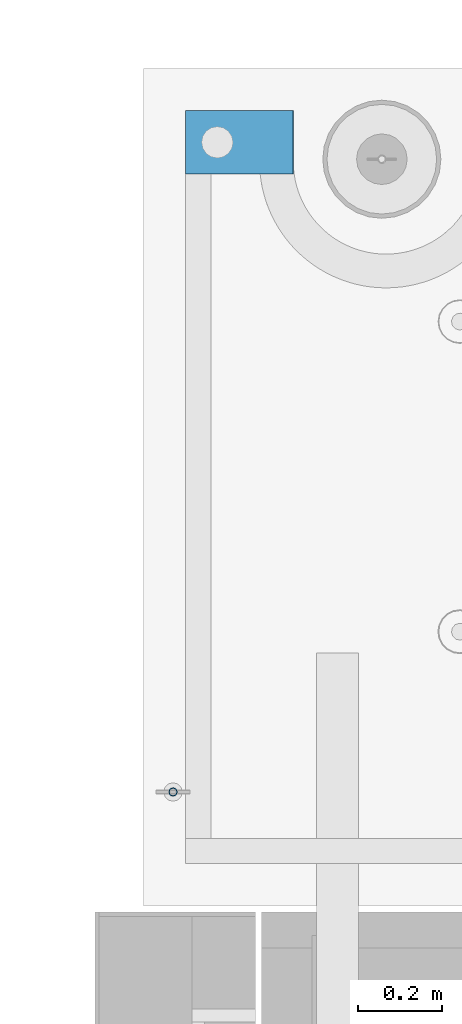
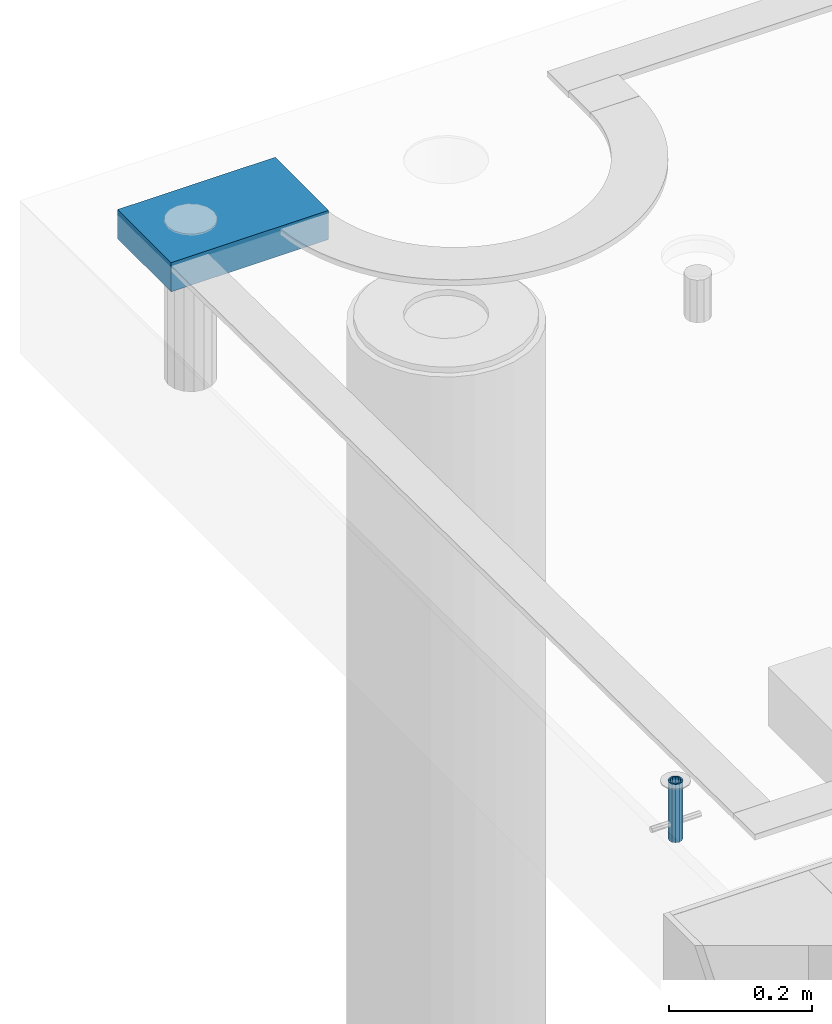
# One storey, part 153 of 352: 2 beams, 2 elements without a shape of their own.
"""IFC2X3 building model written with IfcOpenShell, lengths in millimetres."""

from ifc_helpers import new_model, si_unit, frame, origin_with_axes, place, context, subcontext, project, spatial, faceted_brep, material, type_object, element, aggregate, save


model = new_model("IFC2X3")

# Units and contexts
model_context = context("Model", 3, precision=1e-05, world=origin_with_axes())
body_context = subcontext(model_context, "Body", "Model", "MODEL_VIEW")
ifc_project = project(units=[si_unit("LENGTHUNIT", "METRE", prefix="MILLI"), si_unit("AREAUNIT", "SQUARE_METRE"), si_unit("VOLUMEUNIT", "CUBIC_METRE"), si_unit("MASSUNIT", "GRAM", prefix="KILO"), si_unit("TIMEUNIT", "SECOND"), si_unit("PLANEANGLEUNIT", "RADIAN"), si_unit("SOLIDANGLEUNIT", "STERADIAN"), si_unit("THERMODYNAMICTEMPERATUREUNIT", "DEGREE_CELSIUS"), si_unit("LUMINOUSINTENSITYUNIT", "LUMEN")], contexts=[model_context])

# Site, building, storey
site_placement = place(None, origin_with_axes())
site = spatial("IfcSite", under=ifc_project, at=site_placement, CompositionType="ELEMENT")
building_placement = place(site_placement, origin_with_axes())
building = spatial("IfcBuilding", under=site, at=building_placement, CompositionType="ELEMENT")
storey_placement = place(building_placement, origin_with_axes())
storey = spatial("IfcBuildingStorey", under=building, at=storey_placement, Name="6", CompositionType="ELEMENT", Elevation=0.0)

# Assemblies, beams
assembly_1_placement = place(storey_placement, origin_with_axes())
assembly_1 = element("IfcElementAssembly", 1, at=assembly_1_placement, inside=storey, AssemblyPlace="NOTDEFINED", PredefinedType="REINFORCEMENT_UNIT")
ifc_material_1 = material(Name="CONCRETE/Concrete_Undefined")
beam_type_1 = type_object("IfcBeamType", PredefinedType="NOTDEFINED")
beam_1_placement = place(assembly_1_placement, frame((7834.97852488622, 22709.9981419457, 99691.8130006467), z_axis=(-0.000811736999627788, 6.99999872856177e-09, 0.999999670541467), x_axis=(0.99999967050638, -8.37699998998561e-06, 0.000811736999618736)))
beam_1 = element("IfcBeam", 2, at=beam_1_placement, type_object=beam_type_1, material=ifc_material_1, context=body_context, shape_type="Brep", body=[
    faceted_brep([(0.0, 75.0, -25.0), (1.81898940354586e-12, 75.0, 25.0), (254.995831308013, 74.9999999999964, 24.9999999999709), (254.995831308012, 74.9999999999964, -25.0000000000146), (1.81898940354586e-12, -75.0000000000009, 25.0), (254.995831308014, -75.0000000000036, 24.9999999999854), (0.0, -75.0, -25.0), (254.995831308011, -75.0000000000036, -25.0000000000146)], [[[0, 1, 2, 3]], [[1, 4, 5, 2]], [[4, 6, 7, 5]], [[6, 0, 3, 7]], [[5, 7, 3, 2]], [[6, 4, 1, 0]]]),
])
assembly_2_placement = place(assembly_1_placement, origin_with_axes())
assembly_2 = element("IfcElementAssembly", 3, at=assembly_2_placement, Name="Steel Assembly", AssemblyPlace="NOTDEFINED", PredefinedType="RIGID_FRAME")
aggregate(assembly_1, [assembly_2, beam_1])
ifc_material_2 = material(Name="STEEL/1.4301")
beam_type_2 = type_object("IfcBeamType", PredefinedType="NOTDEFINED")
beam_2_placement = place(assembly_2_placement, frame((7804.99906039055, 21170.0168887753, 99730.9999983246), z_axis=(-1.43919999976435e-05, -0.999999999896435, 0.0), x_axis=(0.0, 0.0, -1.0)))
beam_2 = element("IfcBeam", 4, at=beam_2_placement, type_object=beam_type_2, material=ifc_material_2, context=body_context, shape_type="Brep", body=[
    faceted_brep([(0.0, -8.0, 0.0), (0.0, -6.92820323027263, 4.0), (100.000000000029, -6.92820323027263, 4.0), (100.000000000029, -7.99999999999636, 0.0), (0.0, -4.0, 6.92820323027627), (100.000000000029, -4.0, 6.92820323027536), (0.0, 0.0, 8.0), (100.000000000029, 3.63797880709171e-12, 8.0), (0.0, 4.0, 6.92820323027627), (100.000000000029, 4.0, 6.92820323027536), (0.0, 6.92820323027263, 4.0), (100.000000000029, 6.92820323027627, 3.99999999999909), (0.0, 8.0, 0.0), (100.000000000029, 8.0, 0.0), (0.0, 6.92820323027263, -4.0), (100.000000000029, 6.92820323027627, -4.00000000000091), (0.0, 4.0, -6.92820323027627), (100.000000000029, 4.00000000000364, -6.92820323027536), (0.0, 0.0, -8.0), (100.000000000029, 3.63797880709171e-12, -8.00000000000091), (0.0, -4.0, -6.92820323027627), (100.000000000029, -3.99999999999636, -6.92820323027627), (0.0, -6.92820323027263, -4.0), (100.000000000029, -6.92820323027263, -4.0), (0.0, -10.4999999999927, -1.45519152283669e-11), (0.0, -9.09326673972828, -5.25000000001455), (100.000000000262, -9.09326673972828, -5.25000000001455), (100.000000000262, -10.4999999999927, -1.45519152283669e-11), (0.0, -5.24999999998545, -9.09326673974283), (100.000000000262, -5.24999999998545, -9.09326673974283), (0.0, 7.27595761418343e-12, -10.5), (100.000000000262, 7.27595761418343e-12, -10.5), (0.0, 5.25000000001455, -9.09326673975738), (100.000000000262, 5.25000000001455, -9.09326673975738), (0.0, 9.09326673975011, -5.25000000001455), (100.000000000262, 9.09326673975011, -5.25000000001455), (0.0, 10.5000000000073, -1.45519152283669e-11), (100.000000000262, 10.5000000000073, -1.45519152283669e-11), (0.0, 9.09326673975011, 5.25), (100.000000000262, 9.09326673975011, 5.25), (0.0, 5.25000000000728, 9.09326673972828), (100.000000000262, 5.25000000000728, 9.09326673972828), (0.0, 1.45519152283669e-11, 10.4999999999854), (100.000000000262, 1.45519152283669e-11, 10.4999999999854), (0.0, -5.24999999999272, 9.09326673972828), (100.000000000262, -5.24999999999272, 9.09326673972828), (0.0, -9.09326673972828, 5.24999999998545), (100.000000000262, -9.09326673972828, 5.24999999998545)], [[[0, 1, 2, 3]], [[1, 4, 5, 2]], [[4, 6, 7, 5]], [[6, 8, 9, 7]], [[8, 10, 11, 9]], [[10, 12, 13, 11]], [[12, 14, 15, 13]], [[14, 16, 17, 15]], [[16, 18, 19, 17]], [[18, 20, 21, 19]], [[20, 22, 23, 21]], [[22, 0, 3, 23]], [[24, 25, 26, 27]], [[25, 28, 29, 26]], [[28, 30, 31, 29]], [[30, 32, 33, 31]], [[32, 34, 35, 33]], [[34, 36, 37, 35]], [[36, 38, 39, 37]], [[38, 40, 41, 39]], [[40, 42, 43, 41]], [[42, 44, 45, 43]], [[44, 46, 47, 45]], [[46, 24, 27, 47]], [[29, 31, 33, 35, 37, 39, 41, 43, 45, 47, 27, 26], [5, 7, 9, 11, 13, 15, 17, 19, 21, 23, 3, 2]], [[46, 44, 42, 40, 38, 36, 34, 32, 30, 28, 25, 24], [22, 20, 18, 16, 14, 12, 10, 8, 6, 4, 1, 0]]]),
])
aggregate(assembly_2, [beam_2])

save(model, "model.ifc")
